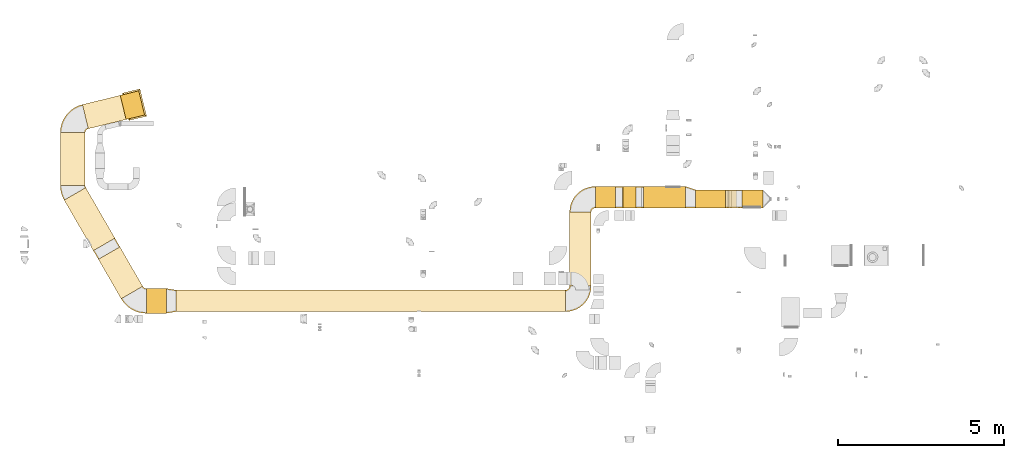
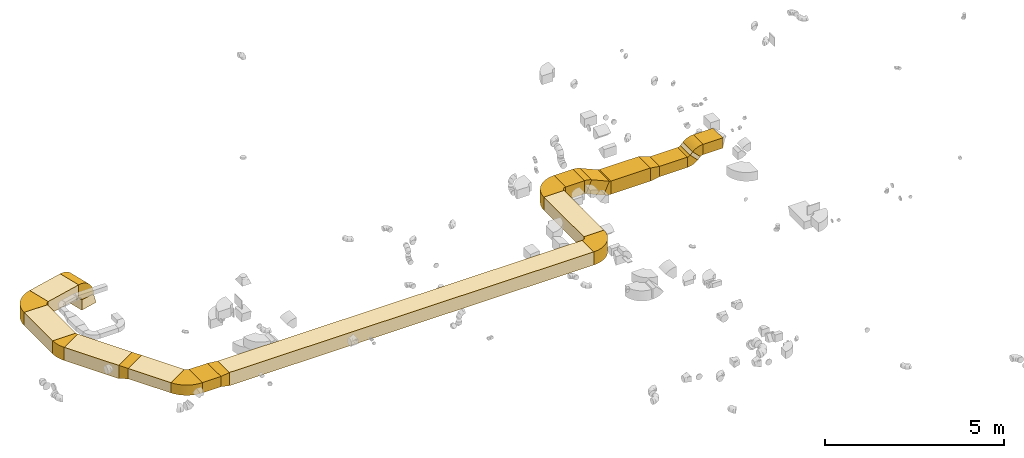
# One storey, part 1 of 44: 27 coverings.
"""IFC2X3 building model written with IfcOpenShell, lengths in millimetres."""

from ifc_helpers import new_model, entity, si_unit, converted_unit, derived_unit, direction, frame, frame_2d, origin, origin_2d_with_axis, place, context, subcontext, project, spatial, polyline, circle_curve, parameter, trimmed, segment, composite_curve, rectangle, outline, extrude, faceted_brep, element, save


model = new_model("IFC2X3")

# Units and contexts
model_context = context("Model", 3, precision=0.01, world=origin(), true_north=direction((6.12303176911189e-17, 1.0)))
body_context = subcontext(model_context, "Body", "Model", "MODEL_VIEW")
ifc_project = project(units=[si_unit("LENGTHUNIT", "METRE", prefix="MILLI"), si_unit("AREAUNIT", "SQUARE_METRE"), si_unit("VOLUMEUNIT", "CUBIC_METRE"), converted_unit("PLANEANGLEUNIT", "DEGREE", entity("IfcRatioMeasure", 0.0174532925199433), si_unit("PLANEANGLEUNIT", "RADIAN"), dimensions=[0, 0, 0, 0, 0, 0, 0]), si_unit("MASSUNIT", "GRAM", prefix="KILO"), derived_unit("MASSDENSITYUNIT", [(si_unit("MASSUNIT", "GRAM", prefix="KILO"), 1), (si_unit("LENGTHUNIT", "METRE"), -3)]), derived_unit("MOMENTOFINERTIAUNIT", [(si_unit("LENGTHUNIT", "METRE"), 4)]), si_unit("TIMEUNIT", "SECOND"), si_unit("FREQUENCYUNIT", "HERTZ"), si_unit("THERMODYNAMICTEMPERATUREUNIT", "DEGREE_CELSIUS"), derived_unit("THERMALTRANSMITTANCEUNIT", [(si_unit("MASSUNIT", "GRAM", prefix="KILO"), 1), (si_unit("THERMODYNAMICTEMPERATUREUNIT", "KELVIN"), -1), (si_unit("TIMEUNIT", "SECOND"), -3)]), derived_unit("VOLUMETRICFLOWRATEUNIT", [(si_unit("LENGTHUNIT", "METRE"), 3), (si_unit("TIMEUNIT", "SECOND"), -1)]), derived_unit("MASSFLOWRATEUNIT", [(si_unit("MASSUNIT", "GRAM", prefix="KILO"), 1), (si_unit("TIMEUNIT", "SECOND"), -1)]), derived_unit("ROTATIONALFREQUENCYUNIT", [(si_unit("TIMEUNIT", "SECOND"), -1)]), si_unit("ELECTRICCURRENTUNIT", "AMPERE"), si_unit("ELECTRICVOLTAGEUNIT", "VOLT"), si_unit("POWERUNIT", "WATT"), si_unit("FORCEUNIT", "NEWTON", prefix="KILO"), si_unit("ILLUMINANCEUNIT", "LUX"), si_unit("LUMINOUSFLUXUNIT", "LUMEN"), si_unit("LUMINOUSINTENSITYUNIT", "CANDELA"), derived_unit("USERDEFINED", [(si_unit("MASSUNIT", "GRAM", prefix="KILO"), -1), (si_unit("LENGTHUNIT", "METRE"), -2), (si_unit("TIMEUNIT", "SECOND"), 3), (si_unit("LUMINOUSFLUXUNIT", "LUMEN"), 1)]), derived_unit("LINEARVELOCITYUNIT", [(si_unit("LENGTHUNIT", "METRE"), 1), (si_unit("TIMEUNIT", "SECOND"), -1)]), si_unit("PRESSUREUNIT", "PASCAL"), derived_unit("USERDEFINED", [(si_unit("LENGTHUNIT", "METRE"), -2), (si_unit("MASSUNIT", "GRAM", prefix="KILO"), 1), (si_unit("TIMEUNIT", "SECOND"), -2)]), derived_unit("LINEARFORCEUNIT", [(si_unit("MASSUNIT", "GRAM", prefix="KILO"), 1), (si_unit("LENGTHUNIT", "METRE"), 1), (si_unit("TIMEUNIT", "SECOND"), -2), (si_unit("LENGTHUNIT", "METRE"), -1)]), derived_unit("PLANARFORCEUNIT", [(si_unit("MASSUNIT", "GRAM", prefix="KILO"), 1), (si_unit("LENGTHUNIT", "METRE"), 1), (si_unit("TIMEUNIT", "SECOND"), -2), (si_unit("LENGTHUNIT", "METRE"), -2)])], contexts=[model_context])

# Site, building, storey
site_placement = place(None, origin())
site = spatial("IfcSite", under=ifc_project, at=site_placement, CompositionType="ELEMENT")
building_placement = place(site_placement, origin())
building = spatial("IfcBuilding", under=site, at=building_placement, CompositionType="ELEMENT")
storey_placement = place(building_placement, frame((0.0, 0.0, 15900.0)))
storey = spatial("IfcBuildingStorey", under=building, at=storey_placement, CompositionType="ELEMENT", Elevation=15900.0)

# Coverings
covering_1_placement = place(storey_placement, frame((2407.46, 13108.63, 3025.0)))
element("IfcCovering", 1, at=covering_1_placement, inside=storey, PredefinedType="INSULATION", context=body_context, shape_type="SweptSolid", body=[
    extrude(rectangle(XDim=1765.48413790719, YDim=749.999999999999, at=origin_2d_with_axis()), frame((766.13, 951.98, 0.0), z_axis=(0.0, 0.0, 1.0), x_axis=(0.499999999999998, -0.86602540378444, 0.0)), (0.0, 0.0, 1.0), 450.000000000002),
])
covering_2_placement = place(storey_placement, frame((5791.73, 11267.03, 3025.0)))
element("IfcCovering", 2, at=covering_2_placement, inside=storey, PredefinedType="INSULATION", context=body_context, shape_type="SweptSolid", body=[
    extrude(rectangle(XDim=11757.7503471403, YDim=650.0, at=origin_2d_with_axis()), frame((5878.88, 325.0, 0.0), z_axis=(0.0, 0.0, 1.0), x_axis=(-1.0, 0.0, 0.0)), (0.0, 0.0, 1.0), 450.000000000002),
])
covering_3_placement = place(storey_placement, frame((17674.48, 12042.03, 3025.0)))
element("IfcCovering", 3, at=covering_3_placement, inside=storey, PredefinedType="INSULATION", context=body_context, shape_type="SweptSolid", body=[
    extrude(rectangle(XDim=2230.86893254484, YDim=650.0, at=origin_2d_with_axis()), frame((325.0, 1115.43, 0.0), z_axis=(0.0, 0.0, 1.0), x_axis=(0.0, 1.0, 0.0)), (0.0, 0.0, 1.0), 450.000000000002),
])
covering_4_placement = place(storey_placement, frame((19907.87, 14397.9, 2715.0)))
element("IfcCovering", 4, at=covering_4_placement, inside=storey, PredefinedType="INSULATION", context=body_context, shape_type="SweptSolid", body=[
    extrude(rectangle(XDim=1271.71476357321, YDim=650.0, at=origin_2d_with_axis()), frame((635.86, 325.0, 0.0)), (0.0, 0.0, 1.0), 450.000000000002),
])
covering_5_placement = place(storey_placement, frame((2290.23, 15075.08, 3025.0)))
element("IfcCovering", 5, at=covering_5_placement, inside=storey, PredefinedType="INSULATION", context=body_context, shape_type="SweptSolid", body=[
    extrude(rectangle(XDim=1595.25442887858, YDim=750.0, at=origin_2d_with_axis()), frame((375.0, 797.63, 0.0), z_axis=(0.0, 0.0, 1.0), x_axis=(0.0, 1.0, 0.0)), (0.0, 0.0, 1.0), 449.999999999999),
])
covering_6_placement = place(storey_placement, frame((2958.01, 16791.78, 3025.0)))
element("IfcCovering", 6, at=covering_6_placement, inside=storey, PredefinedType="INSULATION", context=body_context, shape_type="SweptSolid", body=[
    extrude(rectangle(XDim=1176.32126692913, YDim=750.000000000001, at=origin_2d_with_axis()), frame((660.24, 503.62, 0.0), z_axis=(0.0, 0.0, 1.0), x_axis=(-0.971552058141475, -0.236826092990329, 0.0)), (0.0, 0.0, 1.0), 450.000000000002),
])
covering_7_placement = place(storey_placement, frame((3440.2, 11654.53, 3125.0)))
element("IfcCovering", 7, at=covering_7_placement, inside=storey, PredefinedType="INSULATION", context=body_context, shape_type="SweptSolid", body=[
    extrude(rectangle(XDim=1379.05006941641, YDim=749.999999999998, at=origin_2d_with_axis()), frame((669.52, 784.65, 0.0), z_axis=(0.0, 0.0, 1.0), x_axis=(-0.500000000000022, 0.866025403784426, 0.0)), (0.0, 0.0, 1.0), 349.999999999998),
])
covering_8_placement = place(storey_placement, frame((4887.5, 11217.03, 3125.0)))
element("IfcCovering", 8, at=covering_8_placement, inside=storey, PredefinedType="INSULATION", context=body_context, shape_type="SweptSolid", body=[
    extrude(rectangle(XDim=604.234953933695, YDim=749.999999999998, at=origin_2d_with_axis()), frame((302.12, 375.0, 0.0)), (0.0, 0.0, 1.0), 349.999999999998),
])
covering_9_placement = place(storey_placement, frame((3290.2, 12848.82, 3025.0)))
element("IfcCovering", 9, at=covering_9_placement, inside=storey, PredefinedType="INSULATION", context=body_context, shape_type="SweptSolid", body=[
    extrude(outline(polyline([(-94.87, -189.74), (221.36, -189.74), (79.06, 237.17), (-205.55, 142.3), (-94.87, -189.74)])), frame((75.0, 129.9, 250.0), z_axis=(0.866025403784536, 0.499999999999832, 0.0), x_axis=(-0.474341649025089, 0.821583836257826, -0.316227766016891)), (0.0, 0.0, 1.0), 749.999999999905),
])
covering_10_placement = place(storey_placement, frame((21479.58, 14397.9, 2765.0)))
element("IfcCovering", 10, at=covering_10_placement, inside=storey, PredefinedType="INSULATION", context=body_context, shape_type="SweptSolid", body=[
    extrude(rectangle(XDim=895.634640732672, YDim=550.000000000001, at=origin_2d_with_axis()), frame((447.82, 275.0, 0.0)), (0.0, 0.0, 1.0), 349.999999999998),
])
covering_11_placement = place(storey_placement, frame((18449.48, 14397.9, 3025.0)))
element("IfcCovering", 11, at=covering_11_placement, inside=storey, PredefinedType="INSULATION", context=body_context, shape_type="SweptSolid", body=[
    extrude(rectangle(XDim=606.778443805335, YDim=650.0, at=origin_2d_with_axis()), frame((303.39, 325.0, 0.0)), (0.0, 0.0, 1.0), 450.000000000002),
])
covering_12_placement = place(storey_placement, frame((19106.61, 14397.9, 2763.71)))
element("IfcCovering", 12, at=covering_12_placement, inside=storey, PredefinedType="INSULATION", context=body_context, shape_type="SweptSolid", body=[
    extrude(rectangle(XDim=450.000000000001, YDim=622.364534896965, at=frame_2d((0.0, 0.0), x_axis=(0.0, 1.0))), frame((375.45, 0.0, 331.29), z_axis=(0.0, 1.0, 0.0), x_axis=(0.915282031512424, 0.0, -0.402813608000637)), (0.0, 0.0, 1.0), 650.000000000002),
])
covering_13_placement = place(storey_placement, frame((22463.61, 14397.9, 2904.12)))
element("IfcCovering", 13, at=covering_13_placement, inside=storey, PredefinedType="INSULATION", context=body_context, shape_type="SweptSolid", body=[
    extrude(rectangle(XDim=350.0, YDim=119.166655855303, at=frame_2d((0.0, 0.0), x_axis=(0.0, 1.0))), frame((165.88, 0.0, 165.88), z_axis=(0.0, 1.0, 0.0), x_axis=(0.707106781186566, 0.0, 0.707106781186529)), (0.0, 0.0, 1.0), 550.000000000003),
])
covering_14_placement = place(storey_placement, frame((22883.75, 14397.9, 3025.0)))
element("IfcCovering", 14, at=covering_14_placement, inside=storey, PredefinedType="INSULATION", context=body_context, shape_type="SweptSolid", body=[
    extrude(rectangle(XDim=635.844695138277, YDim=550.000000000001, at=origin_2d_with_axis()), frame((317.92, 275.0, 0.0), z_axis=(0.0, 0.0, 1.0), x_axis=(-1.0, 0.0, 0.0)), (0.0, 0.0, 1.0), 349.999999999998),
])
covering_15_placement = place(storey_placement, frame((4161.89, 17039.55, 2600.0)))
element("IfcCovering", 15, at=covering_15_placement, inside=storey, PredefinedType="INSULATION", context=body_context, shape_type="Brep", body=[
    faceted_brep([(675.24, 166.99, 300.0), (497.62, 895.65, 300.0), (60.42, 789.08, 300.0), (238.04, 60.42, 300.0), (735.66, 130.25, 0.0), (201.3, 0.0, 0.0), (0.0, 825.82, 0.0), (534.35, 956.07, 0.0)], [[[0, 1, 2, 3]], [[4, 5, 6, 7]], [[4, 7, 1, 0]], [[7, 6, 2, 1]], [[6, 5, 3, 2]], [[5, 4, 0, 3]]]),
])
covering_16_placement = place(storey_placement, frame((21179.58, 14397.9, 2715.0)))
element("IfcCovering", 16, at=covering_16_placement, inside=storey, PredefinedType="INSULATION", context=body_context, shape_type="Brep", body=[
    faceted_brep([(300.0, 0.0, 400.0), (300.0, 0.0, 50.0), (300.0, 550.0, 50.0), (300.0, 550.0, 400.0), (0.0, 0.0, 450.0), (0.0, 650.0, 450.0), (0.0, 650.0, 0.0), (0.0, 0.0, 0.0)], [[[0, 1, 2, 3]], [[4, 5, 6, 7]], [[4, 7, 1, 0]], [[7, 6, 2, 1]], [[6, 5, 3, 2]], [[5, 4, 0, 3]]]),
])
covering_17_placement = place(storey_placement, frame((5491.73, 11217.03, 3025.0)))
element("IfcCovering", 17, at=covering_17_placement, inside=storey, PredefinedType="INSULATION", context=body_context, shape_type="Brep", body=[
    faceted_brep([(0.0, 750.0, 450.0), (0.0, 750.0, 100.0), (0.0, 0.0, 100.0), (0.0, 0.0, 450.0), (300.0, 700.0, 450.0), (300.0, 50.0, 450.0), (300.0, 50.0, 0.0), (300.0, 700.0, 0.0)], [[[0, 1, 2, 3]], [[4, 5, 6, 7]], [[4, 7, 1, 0]], [[7, 6, 2, 1]], [[6, 5, 3, 2]], [[5, 4, 0, 3]]]),
])
covering_18_placement = place(storey_placement, frame((2288.63, 14635.99, 3025.0)))
element("IfcCovering", 18, at=covering_18_placement, inside=storey, PredefinedType="INSULATION", context=body_context, shape_type="SweptSolid", body=[
    extrude(outline(composite_curve([segment(polyline([(-358.25, 62.5), (291.27, -312.5)]), True, "CONTINUOUS"), segment(trimmed(circle_curve(frame_2d((-466.51, 125.0), x_axis=(1.0, 0.0)), 875.0), [parameter(330.0)], [parameter(0.0)], True, "PARAMETER"), True, "CONTINUOUS"), segment(polyline([(408.49, 125.0), (-341.51, 125.0)]), True, "CONTINUOUS"), segment(trimmed(circle_curve(frame_2d((-466.51, 125.0), x_axis=(1.0, 0.0)), 125.0), [parameter(330.0)], [parameter(360.0)], True, "PARAMETER"), False, "CONTINUOUS")], self_intersect=False)), frame((410.09, 314.1, 0.0), z_axis=(0.0, 0.0, -1.0), x_axis=(-1.0, 0.0, 0.0)), (0.0, 0.0, -1.0), 450.000000000002),
])
covering_19_placement = place(storey_placement, frame((17672.89, 14271.3, 3025.0)))
element("IfcCovering", 19, at=covering_19_placement, inside=storey, PredefinedType="INSULATION", context=body_context, shape_type="SweptSolid", body=[
    extrude(outline(composite_curve([segment(polyline([(-225.0, 100.0), (-225.0, -550.0)]), True, "CONTINUOUS"), segment(trimmed(circle_curve(frame_2d((-225.0, 225.0), x_axis=(1.0, 0.0)), 775.0), [parameter(270.0)], [parameter(0.0)], True, "PARAMETER"), True, "CONTINUOUS"), segment(polyline([(550.0, 225.0), (-100.0, 225.0)]), True, "CONTINUOUS"), segment(trimmed(circle_curve(frame_2d((-225.0, 225.0), x_axis=(1.0, 0.0)), 125.0), [parameter(270.0)], [parameter(360.0)], True, "PARAMETER"), False, "CONTINUOUS")], self_intersect=False)), frame((551.6, 226.6, 0.0), z_axis=(0.0, 0.0, -1.0), x_axis=(0.0, 1.0, 0.0)), (0.0, 0.0, -1.0), 450.000000000002),
])
covering_20_placement = place(storey_placement, frame((4099.27, 17068.77, 2898.4)))
element("IfcCovering", 20, at=covering_20_placement, inside=storey, PredefinedType="INSULATION", context=body_context, shape_type="SweptSolid", body=[
    extrude(outline(composite_curve([segment(polyline([(-50.0, -175.0), (400.0, -175.0)]), True, "CONTINUOUS"), segment(trimmed(circle_curve(frame_2d((-175.0, -175.0), x_axis=(0.0, 1.0)), 575.0), [parameter(270.0)], [parameter(0.0)], True, "PARAMETER"), True, "CONTINUOUS"), segment(polyline([(-175.0, 400.0), (-175.0, -50.0)]), True, "CONTINUOUS"), segment(trimmed(circle_curve(frame_2d((-175.0, -175.0), x_axis=(0.0, 1.0)), 125.0), [parameter(270.0)], [parameter(360.0)], True, "PARAMETER"), False, "CONTINUOUS")], self_intersect=False)), frame((349.24, 43.04, 176.6), z_axis=(-0.236826092990335, 0.971552058141474, 0.0), x_axis=(0.0, 0.0, 1.0)), (0.0, 0.0, 1.0), 750.000000000002),
])
covering_21_placement = place(storey_placement, frame((2288.63, 16668.74, 3025.0)))
element("IfcCovering", 21, at=covering_21_placement, inside=storey, PredefinedType="INSULATION", context=body_context, shape_type="SweptSolid", body=[
    extrude(outline(composite_curve([segment(polyline([(-279.6, 121.44), (-101.98, -607.22)]), True, "CONTINUOUS"), segment(trimmed(circle_curve(frame_2d((-309.21, 242.89), x_axis=(1.0, 0.0)), 875.0), [parameter(283.699289187458)], [parameter(0.0)], True, "PARAMETER"), True, "CONTINUOUS"), segment(polyline([(565.79, 242.89), (-184.21, 242.89)]), True, "CONTINUOUS"), segment(trimmed(circle_curve(frame_2d((-309.21, 242.89), x_axis=(1.0, 0.0)), 125.0), [parameter(283.699289187458)], [parameter(360.0)], True, "PARAMETER"), False, "CONTINUOUS")], self_intersect=False)), frame((567.39, 244.48, 0.0), z_axis=(0.0, 0.0, -1.0), x_axis=(-0.236826092990327, 0.971552058141475, 0.0)), (0.0, 0.0, -1.0), 450.000000000002),
])
covering_22_placement = place(storey_placement, frame((4128.13, 11215.43, 3125.0)))
element("IfcCovering", 22, at=covering_22_placement, inside=storey, PredefinedType="INSULATION", context=body_context, shape_type="SweptSolid", body=[
    extrude(outline(composite_curve([segment(polyline([(-312.5, 108.25), (62.5, -541.27)]), True, "CONTINUOUS"), segment(trimmed(circle_curve(frame_2d((-375.0, 216.51), x_axis=(1.0, 0.0)), 875.0), [parameter(300.0)], [parameter(0.0)], True, "PARAMETER"), True, "CONTINUOUS"), segment(polyline([(500.0, 216.51), (-250.0, 216.51)]), True, "CONTINUOUS"), segment(trimmed(circle_curve(frame_2d((-375.0, 216.51), x_axis=(1.0, 0.0)), 125.0), [parameter(300.0)], [parameter(360.0)], True, "PARAMETER"), False, "CONTINUOUS")], self_intersect=False)), frame((542.86, 501.6, 0.0), z_axis=(0.0, 0.0, -1.0), x_axis=(-0.866025403784422, -0.500000000000028, 0.0)), (0.0, 0.0, -1.0), 349.999999999998),
])
covering_23_placement = place(storey_placement, frame((19054.66, 14397.9, 3012.81)))
element("IfcCovering", 23, at=covering_23_placement, inside=storey, PredefinedType="INSULATION", context=body_context, shape_type="SweptSolid", body=[
    extrude(outline(composite_curve([segment(polyline([(-220.76, 20.14), (191.11, -161.13)]), True, "CONTINUOUS"), segment(trimmed(circle_curve(frame_2d((-335.17, 70.49), x_axis=(1.0, 0.0)), 575.0), [parameter(336.245811055729)], [parameter(0.0)], True, "PARAMETER"), True, "CONTINUOUS"), segment(polyline([(239.83, 70.49), (-210.17, 70.49)]), True, "CONTINUOUS"), segment(trimmed(circle_curve(frame_2d((-335.17, 70.49), x_axis=(1.0, 0.0)), 125.0), [parameter(336.245811055729)], [parameter(360.0)], True, "PARAMETER"), False, "CONTINUOUS")], self_intersect=False)), frame((72.09, 0.0, 222.36), z_axis=(0.0, -1.0, 0.0), x_axis=(0.0, 0.0, 1.0)), (0.0, 0.0, -1.0), 650.0),
])
covering_24_placement = place(storey_placement, frame((19674.66, 14397.9, 2713.41)))
element("IfcCovering", 24, at=covering_24_placement, inside=storey, PredefinedType="INSULATION", context=body_context, shape_type="SweptSolid", body=[
    extrude(outline(composite_curve([segment(polyline([(-220.76, 20.14), (191.11, -161.13)]), True, "CONTINUOUS"), segment(trimmed(circle_curve(frame_2d((-335.17, 70.49), x_axis=(1.0, 0.0)), 575.0), [parameter(336.245811055729)], [parameter(0.0)], True, "PARAMETER"), True, "CONTINUOUS"), segment(polyline([(239.83, 70.49), (-210.17, 70.49)]), True, "CONTINUOUS"), segment(trimmed(circle_curve(frame_2d((-335.17, 70.49), x_axis=(1.0, 0.0)), 125.0), [parameter(336.245811055729)], [parameter(360.0)], True, "PARAMETER"), False, "CONTINUOUS")], self_intersect=False)), frame((162.72, 0.0, 241.42), z_axis=(0.0, -1.0, 0.0), x_axis=(0.0, 0.0, -1.0)), (0.0, 0.0, -1.0), 650.0),
])
covering_25_placement = place(storey_placement, frame((22373.62, 14397.9, 2763.41)))
element("IfcCovering", 25, at=covering_25_placement, inside=storey, PredefinedType="INSULATION", context=body_context, shape_type="SweptSolid", body=[
    extrude(outline(composite_curve([segment(polyline([(-131.07, -106.07), (218.93, -106.07)]), True, "CONTINUOUS"), segment(trimmed(circle_curve(frame_2d((-256.07, -106.07), x_axis=(0.707106781186525, 0.707106781186496)), 475.0), [parameter(315.0)], [parameter(0.0)], True, "PARAMETER"), True, "CONTINUOUS"), segment(polyline([(79.81, 229.81), (-167.68, -17.68)]), True, "CONTINUOUS"), segment(trimmed(circle_curve(frame_2d((-256.07, -106.07), x_axis=(0.707106781186525, 0.707106781186496)), 125.0), [parameter(315.0)], [parameter(360.0)], True, "PARAMETER"), False, "CONTINUOUS")], self_intersect=False)), frame((107.66, 0.0, 220.53), z_axis=(0.0, 1.0, 0.0), x_axis=(0.707106781186548, 0.0, -0.707106781186548)), (0.0, 0.0, 1.0), 550.000000000001),
])
covering_26_placement = place(storey_placement, frame((22546.27, 14397.9, 2986.79)))
element("IfcCovering", 26, at=covering_26_placement, inside=storey, PredefinedType="INSULATION", context=body_context, shape_type="SweptSolid", body=[
    extrude(outline(composite_curve([segment(polyline([(-167.68, 17.68), (79.81, -229.81)]), True, "CONTINUOUS"), segment(trimmed(circle_curve(frame_2d((-256.07, 106.07), x_axis=(1.0, 0.0)), 475.0), [parameter(315.0)], [parameter(0.0)], True, "PARAMETER"), True, "CONTINUOUS"), segment(polyline([(218.93, 106.07), (-131.07, 106.07)]), True, "CONTINUOUS"), segment(trimmed(circle_curve(frame_2d((-256.07, 106.07), x_axis=(1.0, 0.0)), 125.0), [parameter(315.0)], [parameter(360.0)], True, "PARAMETER"), False, "CONTINUOUS")], self_intersect=False)), frame((231.4, 0.0, 169.27), z_axis=(0.0, -1.0, 0.0), x_axis=(-0.707106781187445, 0.0, 0.70710678118565)), (0.0, 0.0, -1.0), 550.0),
])
covering_27_placement = place(storey_placement, frame((17547.89, 11265.43, 3025.0)))
element("IfcCovering", 27, at=covering_27_placement, inside=storey, PredefinedType="INSULATION", context=body_context, shape_type="SweptSolid", body=[
    extrude(outline(composite_curve([segment(polyline([(-225.0, 100.0), (-225.0, -550.0)]), True, "CONTINUOUS"), segment(trimmed(circle_curve(frame_2d((-225.0, 225.0), x_axis=(1.0, 0.0)), 775.0), [parameter(270.0)], [parameter(0.0)], True, "PARAMETER"), True, "CONTINUOUS"), segment(polyline([(550.0, 225.0), (-100.0, 225.0)]), True, "CONTINUOUS"), segment(trimmed(circle_curve(frame_2d((-225.0, 225.0), x_axis=(1.0, 0.0)), 125.0), [parameter(270.0)], [parameter(360.0)], True, "PARAMETER"), False, "CONTINUOUS")], self_intersect=False)), frame((226.6, 551.6, 0.0), z_axis=(0.0, 0.0, -1.0), x_axis=(0.0, -1.0, 0.0)), (0.0, 0.0, -1.0), 450.000000000002),
])

save(model, "model.ifc")
